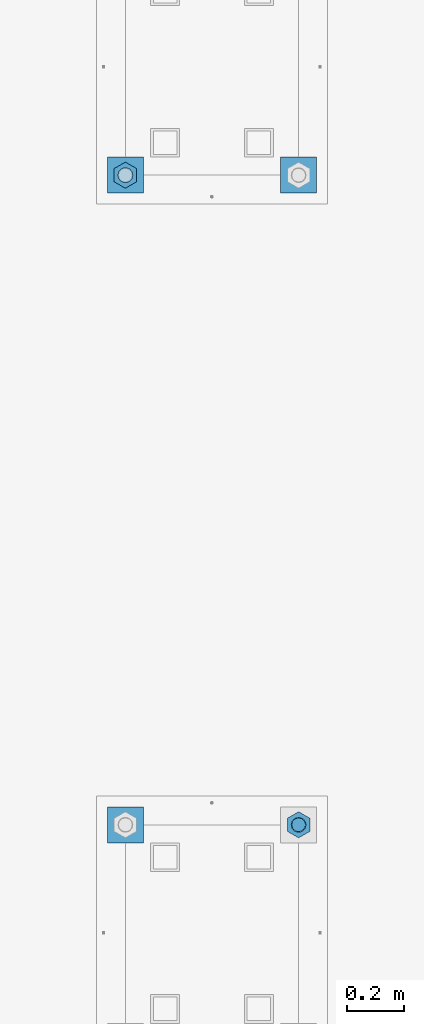
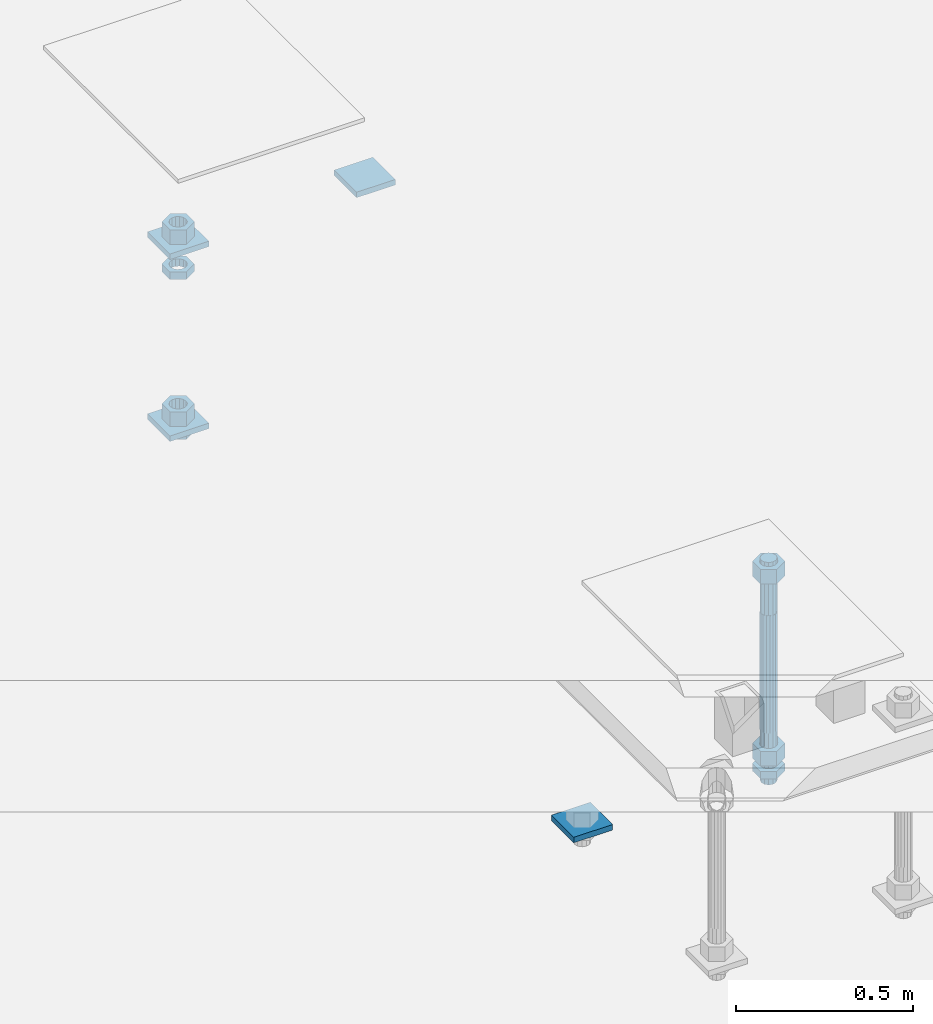
# One storey, part 2638 of 3843: 12 beams, 2 elements without a shape of their own.
"""IFC2X3 building model written with IfcOpenShell, lengths in millimetres."""

from ifc_helpers import new_model, si_unit, frame, origin_with_axes, place, context, subcontext, project, spatial, faceted_brep, material, type_object, element, aggregate, save


model = new_model("IFC2X3")

# Units and contexts
model_context = context("Model", 3, precision=1e-05, world=origin_with_axes())
body_context = subcontext(model_context, "Body", "Model", "MODEL_VIEW")
ifc_project = project(units=[si_unit("LENGTHUNIT", "METRE", prefix="MILLI"), si_unit("AREAUNIT", "SQUARE_METRE"), si_unit("VOLUMEUNIT", "CUBIC_METRE"), si_unit("MASSUNIT", "GRAM", prefix="KILO"), si_unit("TIMEUNIT", "SECOND"), si_unit("PLANEANGLEUNIT", "RADIAN"), si_unit("SOLIDANGLEUNIT", "STERADIAN"), si_unit("THERMODYNAMICTEMPERATUREUNIT", "DEGREE_CELSIUS"), si_unit("LUMINOUSINTENSITYUNIT", "LUMEN")], contexts=[model_context])

# Site, building, storey
site_placement = place(None, origin_with_axes())
site = spatial("IfcSite", under=ifc_project, at=site_placement, CompositionType="ELEMENT")
building_placement = place(site_placement, origin_with_axes())
building = spatial("IfcBuilding", under=site, at=building_placement, Name="Undefined", CompositionType="ELEMENT")
storey_placement = place(building_placement, origin_with_axes())
storey = spatial("IfcBuildingStorey", under=building, at=storey_placement, Name="Undefined", CompositionType="ELEMENT", Elevation=0.0)

# Assembly, beams
assembly_1_placement = place(storey_placement, origin_with_axes())
assembly_1 = element("IfcElementAssembly", 1, at=assembly_1_placement, inside=storey, Name="TEMPLATE", AssemblyPlace="NOTDEFINED", PredefinedType="RIGID_FRAME")
ifc_material_1 = material(Name="STEEL/A36")
beam_type_1 = type_object("IfcBeamType", PredefinedType="NOTDEFINED")
beam_1_placement = place(assembly_1_placement, frame((111798.099998474, 10121.9, 29873.575), z_axis=(0.0, 1.0, 0.0), x_axis=(-1.0, 0.0, 0.0)))
beam_1 = element("IfcBeam", 2, at=beam_1_placement, type_object=beam_type_1, material=ifc_material_1, Name="WASHER_PLATE", context=body_context, shape_type="Brep", body=[
    faceted_brep([(0.0, 9.52500000000146, -63.5), (0.0, 9.52500000000146, 63.5), (127.0, 9.52500000000146, 63.5), (127.0, 9.52500000000146, -63.5), (0.0, -9.52500000000146, 63.5), (127.0, -9.52500000000146, 63.5), (0.0, -9.52500000000146, -63.5), (127.0, -9.52500000000146, -63.5)], [[[0, 1, 2, 3]], [[1, 4, 5, 2]], [[4, 6, 7, 5]], [[6, 0, 3, 7]], [[5, 7, 3, 2]], [[6, 4, 1, 0]]]),
])
beam_2_placement = place(assembly_1_placement, frame((112407.7, 10121.9, 29873.575), z_axis=(0.0, 1.0, 0.0), x_axis=(-1.0, 0.0, 0.0)))
beam_2 = element("IfcBeam", 3, at=beam_2_placement, type_object=beam_type_1, material=ifc_material_1, Name="WASHER_PLATE", context=body_context, shape_type="Brep", body=[
    faceted_brep([(0.0, 9.52500000000146, -63.5), (0.0, 9.52500000000146, 63.5), (127.0, 9.52500000000146, 63.5), (127.0, 9.52500000000146, -63.5), (0.0, -9.52500000000146, 63.5), (127.0, -9.52500000000146, 63.5), (0.0, -9.52500000000146, -63.5), (127.0, -9.52500000000146, -63.5)], [[[0, 1, 2, 3]], [[1, 4, 5, 2]], [[4, 6, 7, 5]], [[6, 0, 3, 7]], [[5, 7, 3, 2]], [[6, 4, 1, 0]]]),
])
beam_3_placement = place(assembly_1_placement, frame((111798.099998474, 10121.9, 29244.925), z_axis=(0.0, 1.0, 0.0), x_axis=(-1.0, 0.0, 0.0)))
beam_3 = element("IfcBeam", 4, at=beam_3_placement, type_object=beam_type_1, material=ifc_material_1, Name="WASHER_PLATE", context=body_context, shape_type="Brep", body=[
    faceted_brep([(0.0, 9.52500000000146, -63.5), (0.0, 9.52500000000146, 63.5), (127.0, 9.52500000000146, 63.5), (127.0, 9.52500000000146, -63.5), (0.0, -9.52500000000146, 63.5), (127.0, -9.52500000000146, 63.5), (0.0, -9.52500000000146, -63.5), (127.0, -9.52500000000146, -63.5)], [[[0, 1, 2, 3]], [[1, 4, 5, 2]], [[4, 6, 7, 5]], [[6, 0, 3, 7]], [[5, 7, 3, 2]], [[6, 4, 1, 0]]]),
])

# Assembly, beam
assembly_2_placement = place(storey_placement, origin_with_axes())
assembly_2 = element("IfcElementAssembly", 5, at=assembly_2_placement, inside=storey, Name="TEMPLATE", AssemblyPlace="NOTDEFINED", PredefinedType="RIGID_FRAME")
beam_4_placement = place(assembly_2_placement, frame((111798.099998474, 7835.90000000001, 29244.925), z_axis=(0.0, 1.0, 0.0), x_axis=(-1.0, 0.0, 0.0)))
beam_4 = element("IfcBeam", 6, at=beam_4_placement, type_object=beam_type_1, material=ifc_material_1, Name="WASHER_PLATE", context=body_context, shape_type="Brep", body=[
    faceted_brep([(0.0, 9.52500000000146, -63.5), (0.0, 9.52500000000146, 63.5), (127.0, 9.52500000000146, 63.5), (127.0, 9.52500000000146, -63.5), (0.0, -9.52500000000146, 63.5), (127.0, -9.52500000000146, 63.5), (0.0, -9.52500000000146, -63.5), (127.0, -9.52500000000146, -63.5)], [[[0, 1, 2, 3]], [[1, 4, 5, 2]], [[4, 6, 7, 5]], [[6, 0, 3, 7]], [[5, 7, 3, 2]], [[6, 4, 1, 0]]]),
])

# Beam
beam_type_2 = type_object("IfcBeamType", Name="2_HALF_NUT", PredefinedType="NOTDEFINED")
beam_5_placement = place(assembly_1_placement, frame((111734.599998474, 10121.9, 29787.85), z_axis=(-1.0, 0.0, 0.0), x_axis=(0.0, 0.0, -1.0)))
beam_5 = element("IfcBeam", 7, at=beam_5_placement, type_object=beam_type_2, material=ifc_material_1, Name="NUT", ObjectType="2_HALF_NUT", context=body_context, shape_type="Brep", body=[
    faceted_brep([(0.0, -46.0369987487793, 0.0), (0.0, -23.0184993743896, -39.869213104248), (25.4000000000015, -23.0184993743896, -39.869213104248), (25.4000000000015, -46.0369987487793, 0.0), (0.0, 23.0184993743896, -39.869213104248), (25.4000000000015, 23.0184993743896, -39.869213104248), (0.0, 46.0369987487793, 0.0), (25.4000000000015, 46.0369987487793, 0.0), (0.0, 23.0184993743896, 39.869213104248), (25.4000000000015, 23.0184993743896, 39.869213104248), (0.0, -23.0184993743896, 39.869213104248), (25.4000000000015, -23.0184993743896, 39.869213104248), (0.0, 0.0, 26.1940002441406), (0.0, 11.3650617044477, 23.5999013092805), (25.4000000000015, 11.3650617044477, 23.5999013092805), (25.4000000000015, 0.0, 26.1940002441406), (0.0, 20.4791109456419, 16.3316083006721), (25.4000000000015, 20.4791109456419, 16.3316083006721), (0.0, 25.5370200498292, 5.82867859874386), (25.4000000000015, 25.5370200498292, 5.82867859874386), (0.0, 25.5370200498292, -5.82867859874386), (25.4000000000015, 25.5370200498292, -5.82867859874386), (0.0, 20.4791109456419, -16.3316083006721), (25.4000000000015, 20.4791109456419, -16.3316083006721), (0.0, 11.3650617044477, -23.5999013092805), (25.4000000000015, 11.3650617044477, -23.5999013092805), (0.0, 0.0, -26.1940002441406), (25.4000000000015, 0.0, -26.1940002441406), (0.0, -11.3650617044477, -23.5999013092805), (25.4000000000015, -11.3650617044477, -23.5999013092805), (0.0, -20.4791109456419, -16.3316083006721), (25.4000000000015, -20.4791109456419, -16.3316083006721), (0.0, -25.5370200498292, -5.82867859874386), (25.4000000000015, -25.5370200498292, -5.82867859874386), (0.0, -25.5370200498292, 5.82867859874386), (25.4000000000015, -25.5370200498292, 5.82867859874386), (0.0, -20.4791109456419, 16.3316083006721), (25.4000000000015, -20.4791109456419, 16.3316083006721), (0.0, -11.3650617044477, 23.5999013092805), (25.4000000000015, -11.3650617044477, 23.5999013092805)], [[[0, 1, 2, 3]], [[1, 4, 5, 2]], [[4, 6, 7, 5]], [[6, 8, 9, 7]], [[8, 10, 11, 9]], [[10, 0, 3, 11]], [[12, 13, 14, 15]], [[13, 16, 17, 14]], [[16, 18, 19, 17]], [[18, 20, 21, 19]], [[20, 22, 23, 21]], [[22, 24, 25, 23]], [[24, 26, 27, 25]], [[26, 28, 29, 27]], [[28, 30, 31, 29]], [[30, 32, 33, 31]], [[32, 34, 35, 33]], [[34, 36, 37, 35]], [[36, 38, 39, 37]], [[38, 12, 15, 39]], [[5, 7, 9, 11, 3, 2], [17, 19, 21, 23, 25, 27, 29, 31, 33, 35, 37, 39, 15, 14]], [[10, 8, 6, 4, 1, 0], [38, 36, 34, 32, 30, 28, 26, 24, 22, 20, 18, 16, 13, 12]]]),
])

beam_6_placement = place(assembly_1_placement, frame((111734.599998474, 10121.9, 29235.4), z_axis=(-1.0, 0.0, 0.0), x_axis=(0.0, 0.0, -1.0)))
beam_6 = element("IfcBeam", 8, at=beam_6_placement, type_object=beam_type_2, material=ifc_material_1, Name="NUT", ObjectType="2_HALF_NUT", context=body_context, shape_type="Brep", body=[
    faceted_brep([(0.0, -46.0369987487793, 0.0), (0.0, -23.0184993743896, -39.869213104248), (25.4000000000015, -23.0184993743896, -39.869213104248), (25.4000000000015, -46.0369987487793, 0.0), (0.0, 23.0184993743896, -39.869213104248), (25.4000000000015, 23.0184993743896, -39.869213104248), (0.0, 46.0369987487793, 0.0), (25.4000000000015, 46.0369987487793, 0.0), (0.0, 23.0184993743896, 39.869213104248), (25.4000000000015, 23.0184993743896, 39.869213104248), (0.0, -23.0184993743896, 39.869213104248), (25.4000000000015, -23.0184993743896, 39.869213104248), (0.0, 0.0, 26.1940002441406), (0.0, 11.3650617044477, 23.5999013092805), (25.4000000000015, 11.3650617044477, 23.5999013092805), (25.4000000000015, 0.0, 26.1940002441406), (0.0, 20.4791109456419, 16.3316083006721), (25.4000000000015, 20.4791109456419, 16.3316083006721), (0.0, 25.5370200498292, 5.82867859874386), (25.4000000000015, 25.5370200498292, 5.82867859874386), (0.0, 25.5370200498292, -5.82867859874386), (25.4000000000015, 25.5370200498292, -5.82867859874386), (0.0, 20.4791109456419, -16.3316083006721), (25.4000000000015, 20.4791109456419, -16.3316083006721), (0.0, 11.3650617044477, -23.5999013092805), (25.4000000000015, 11.3650617044477, -23.5999013092805), (0.0, 0.0, -26.1940002441406), (25.4000000000015, 0.0, -26.1940002441406), (0.0, -11.3650617044477, -23.5999013092805), (25.4000000000015, -11.3650617044477, -23.5999013092805), (0.0, -20.4791109456419, -16.3316083006721), (25.4000000000015, -20.4791109456419, -16.3316083006721), (0.0, -25.5370200498292, -5.82867859874386), (25.4000000000015, -25.5370200498292, -5.82867859874386), (0.0, -25.5370200498292, 5.82867859874386), (25.4000000000015, -25.5370200498292, 5.82867859874386), (0.0, -20.4791109456419, 16.3316083006721), (25.4000000000015, -20.4791109456419, 16.3316083006721), (0.0, -11.3650617044477, 23.5999013092805), (25.4000000000015, -11.3650617044477, 23.5999013092805)], [[[0, 1, 2, 3]], [[1, 4, 5, 2]], [[4, 6, 7, 5]], [[6, 8, 9, 7]], [[8, 10, 11, 9]], [[10, 0, 3, 11]], [[12, 13, 14, 15]], [[13, 16, 17, 14]], [[16, 18, 19, 17]], [[18, 20, 21, 19]], [[20, 22, 23, 21]], [[22, 24, 25, 23]], [[24, 26, 27, 25]], [[26, 28, 29, 27]], [[28, 30, 31, 29]], [[30, 32, 33, 31]], [[32, 34, 35, 33]], [[34, 36, 37, 35]], [[36, 38, 39, 37]], [[38, 12, 15, 39]], [[5, 7, 9, 11, 3, 2], [17, 19, 21, 23, 25, 27, 29, 31, 33, 35, 37, 39, 15, 14]], [[10, 8, 6, 4, 1, 0], [38, 36, 34, 32, 30, 28, 26, 24, 22, 20, 18, 16, 13, 12]]]),
])

beam_7_placement = place(assembly_2_placement, frame((112344.2, 7835.9, 29235.4), z_axis=(-1.0, 0.0, 0.0), x_axis=(0.0, 0.0, -1.0)))
beam_7 = element("IfcBeam", 9, at=beam_7_placement, type_object=beam_type_2, material=ifc_material_1, Name="NUT", ObjectType="2_HALF_NUT", context=body_context, shape_type="Brep", body=[
    faceted_brep([(0.0, -46.0369987487793, 0.0), (0.0, -23.0184993743896, -39.869213104248), (25.4000000000015, -23.0184993743896, -39.869213104248), (25.4000000000015, -46.0369987487793, 0.0), (0.0, 23.0184993743896, -39.869213104248), (25.4000000000015, 23.0184993743896, -39.869213104248), (0.0, 46.0369987487793, 0.0), (25.4000000000015, 46.0369987487793, 0.0), (0.0, 23.0184993743896, 39.869213104248), (25.4000000000015, 23.0184993743896, 39.869213104248), (0.0, -23.0184993743896, 39.869213104248), (25.4000000000015, -23.0184993743896, 39.869213104248), (0.0, 0.0, 26.1940002441406), (0.0, 11.3650617044477, 23.5999013092805), (25.4000000000015, 11.3650617044477, 23.5999013092805), (25.4000000000015, 0.0, 26.1940002441406), (0.0, 20.4791109456419, 16.3316083006721), (25.4000000000015, 20.4791109456419, 16.3316083006721), (0.0, 25.5370200498292, 5.82867859874386), (25.4000000000015, 25.5370200498292, 5.82867859874386), (0.0, 25.5370200498292, -5.82867859874386), (25.4000000000015, 25.5370200498292, -5.82867859874386), (0.0, 20.4791109456419, -16.3316083006721), (25.4000000000015, 20.4791109456419, -16.3316083006721), (0.0, 11.3650617044477, -23.5999013092805), (25.4000000000015, 11.3650617044477, -23.5999013092805), (0.0, 0.0, -26.1940002441406), (25.4000000000015, 0.0, -26.1940002441406), (0.0, -11.3650617044477, -23.5999013092805), (25.4000000000015, -11.3650617044477, -23.5999013092805), (0.0, -20.4791109456419, -16.3316083006721), (25.4000000000015, -20.4791109456419, -16.3316083006721), (0.0, -25.5370200498292, -5.82867859874386), (25.4000000000015, -25.5370200498292, -5.82867859874386), (0.0, -25.5370200498292, 5.82867859874386), (25.4000000000015, -25.5370200498292, 5.82867859874386), (0.0, -20.4791109456419, 16.3316083006721), (25.4000000000015, -20.4791109456419, 16.3316083006721), (0.0, -11.3650617044477, 23.5999013092805), (25.4000000000015, -11.3650617044477, 23.5999013092805)], [[[0, 1, 2, 3]], [[1, 4, 5, 2]], [[4, 6, 7, 5]], [[6, 8, 9, 7]], [[8, 10, 11, 9]], [[10, 0, 3, 11]], [[12, 13, 14, 15]], [[13, 16, 17, 14]], [[16, 18, 19, 17]], [[18, 20, 21, 19]], [[20, 22, 23, 21]], [[22, 24, 25, 23]], [[24, 26, 27, 25]], [[26, 28, 29, 27]], [[28, 30, 31, 29]], [[30, 32, 33, 31]], [[32, 34, 35, 33]], [[34, 36, 37, 35]], [[36, 38, 39, 37]], [[38, 12, 15, 39]], [[5, 7, 9, 11, 3, 2], [17, 19, 21, 23, 25, 27, 29, 31, 33, 35, 37, 39, 15, 14]], [[10, 8, 6, 4, 1, 0], [38, 36, 34, 32, 30, 28, 26, 24, 22, 20, 18, 16, 13, 12]]]),
])

beam_type_3 = type_object("IfcBeamType", Name="2_HEAVY_HEX_NUT", PredefinedType="NOTDEFINED")
beam_8_placement = place(assembly_1_placement, frame((111734.599998474, 10121.9, 29933.9), z_axis=(-1.0, 0.0, 0.0), x_axis=(0.0, 0.0, -1.0)))
beam_8 = element("IfcBeam", 10, at=beam_8_placement, type_object=beam_type_3, material=ifc_material_1, Name="NUT", ObjectType="2_HEAVY_HEX_NUT", context=body_context, shape_type="Brep", body=[
    faceted_brep([(0.0, -46.0369987487793, 0.0), (0.0, -23.0184993743896, -39.869213104248), (50.7999999999993, -23.0184993743896, -39.869213104248), (50.7999999999993, -46.0369987487793, 0.0), (0.0, 23.0184993743896, -39.869213104248), (50.7999999999993, 23.0184993743896, -39.869213104248), (0.0, 46.0369987487793, 0.0), (50.7999999999993, 46.0369987487793, 0.0), (0.0, 23.0184993743896, 39.869213104248), (50.7999999999993, 23.0184993743896, 39.869213104248), (0.0, -23.0184993743896, 39.869213104248), (50.7999999999993, -23.0184993743896, 39.869213104248), (0.0, 0.0, 26.1940002441406), (0.0, 11.3650617044477, 23.5999013092805), (50.7999999999993, 11.3650617044477, 23.5999013092805), (50.7999999999993, 0.0, 26.1940002441406), (0.0, 20.4791109456419, 16.3316083006721), (50.7999999999993, 20.4791109456419, 16.3316083006721), (0.0, 25.5370200498292, 5.82867859874386), (50.7999999999993, 25.5370200498292, 5.82867859874386), (0.0, 25.5370200498292, -5.82867859874386), (50.7999999999993, 25.5370200498292, -5.82867859874386), (0.0, 20.4791109456419, -16.3316083006721), (50.7999999999993, 20.4791109456419, -16.3316083006721), (0.0, 11.3650617044477, -23.5999013092805), (50.7999999999993, 11.3650617044477, -23.5999013092805), (0.0, 0.0, -26.1940002441406), (50.7999999999993, 0.0, -26.1940002441406), (0.0, -11.3650617044477, -23.5999013092805), (50.7999999999993, -11.3650617044477, -23.5999013092805), (0.0, -20.4791109456419, -16.3316083006721), (50.7999999999993, -20.4791109456419, -16.3316083006721), (0.0, -25.5370200498292, -5.82867859874386), (50.7999999999993, -25.5370200498292, -5.82867859874386), (0.0, -25.5370200498292, 5.82867859874386), (50.7999999999993, -25.5370200498292, 5.82867859874386), (0.0, -20.4791109456419, 16.3316083006721), (50.7999999999993, -20.4791109456419, 16.3316083006721), (0.0, -11.3650617044477, 23.5999013092805), (50.7999999999993, -11.3650617044477, 23.5999013092805)], [[[0, 1, 2, 3]], [[1, 4, 5, 2]], [[4, 6, 7, 5]], [[6, 8, 9, 7]], [[8, 10, 11, 9]], [[10, 0, 3, 11]], [[12, 13, 14, 15]], [[13, 16, 17, 14]], [[16, 18, 19, 17]], [[18, 20, 21, 19]], [[20, 22, 23, 21]], [[22, 24, 25, 23]], [[24, 26, 27, 25]], [[26, 28, 29, 27]], [[28, 30, 31, 29]], [[30, 32, 33, 31]], [[32, 34, 35, 33]], [[34, 36, 37, 35]], [[36, 38, 39, 37]], [[38, 12, 15, 39]], [[5, 7, 9, 11, 3, 2], [17, 19, 21, 23, 25, 27, 29, 31, 33, 35, 37, 39, 15, 14]], [[10, 8, 6, 4, 1, 0], [38, 36, 34, 32, 30, 28, 26, 24, 22, 20, 18, 16, 13, 12]]]),
])

beam_9_placement = place(assembly_1_placement, frame((111734.599998474, 10121.9, 29305.25), z_axis=(-1.0, 0.0, 0.0), x_axis=(0.0, 0.0, -1.0)))
beam_9 = element("IfcBeam", 11, at=beam_9_placement, type_object=beam_type_3, material=ifc_material_1, Name="NUT", ObjectType="2_HEAVY_HEX_NUT", context=body_context, shape_type="Brep", body=[
    faceted_brep([(0.0, -46.0369987487793, 0.0), (0.0, -23.0184993743896, -39.869213104248), (50.7999999999993, -23.0184993743896, -39.869213104248), (50.7999999999993, -46.0369987487793, 0.0), (0.0, 23.0184993743896, -39.869213104248), (50.7999999999993, 23.0184993743896, -39.869213104248), (0.0, 46.0369987487793, 0.0), (50.7999999999993, 46.0369987487793, 0.0), (0.0, 23.0184993743896, 39.869213104248), (50.7999999999993, 23.0184993743896, 39.869213104248), (0.0, -23.0184993743896, 39.869213104248), (50.7999999999993, -23.0184993743896, 39.869213104248), (0.0, 0.0, 26.1940002441406), (0.0, 11.3650617044477, 23.5999013092805), (50.7999999999993, 11.3650617044477, 23.5999013092805), (50.7999999999993, 0.0, 26.1940002441406), (0.0, 20.4791109456419, 16.3316083006721), (50.7999999999993, 20.4791109456419, 16.3316083006721), (0.0, 25.5370200498292, 5.82867859874386), (50.7999999999993, 25.5370200498292, 5.82867859874386), (0.0, 25.5370200498292, -5.82867859874386), (50.7999999999993, 25.5370200498292, -5.82867859874386), (0.0, 20.4791109456419, -16.3316083006721), (50.7999999999993, 20.4791109456419, -16.3316083006721), (0.0, 11.3650617044477, -23.5999013092805), (50.7999999999993, 11.3650617044477, -23.5999013092805), (0.0, 0.0, -26.1940002441406), (50.7999999999993, 0.0, -26.1940002441406), (0.0, -11.3650617044477, -23.5999013092805), (50.7999999999993, -11.3650617044477, -23.5999013092805), (0.0, -20.4791109456419, -16.3316083006721), (50.7999999999993, -20.4791109456419, -16.3316083006721), (0.0, -25.5370200498292, -5.82867859874386), (50.7999999999993, -25.5370200498292, -5.82867859874386), (0.0, -25.5370200498292, 5.82867859874386), (50.7999999999993, -25.5370200498292, 5.82867859874386), (0.0, -20.4791109456419, 16.3316083006721), (50.7999999999993, -20.4791109456419, 16.3316083006721), (0.0, -11.3650617044477, 23.5999013092805), (50.7999999999993, -11.3650617044477, 23.5999013092805)], [[[0, 1, 2, 3]], [[1, 4, 5, 2]], [[4, 6, 7, 5]], [[6, 8, 9, 7]], [[8, 10, 11, 9]], [[10, 0, 3, 11]], [[12, 13, 14, 15]], [[13, 16, 17, 14]], [[16, 18, 19, 17]], [[18, 20, 21, 19]], [[20, 22, 23, 21]], [[22, 24, 25, 23]], [[24, 26, 27, 25]], [[26, 28, 29, 27]], [[28, 30, 31, 29]], [[30, 32, 33, 31]], [[32, 34, 35, 33]], [[34, 36, 37, 35]], [[36, 38, 39, 37]], [[38, 12, 15, 39]], [[5, 7, 9, 11, 3, 2], [17, 19, 21, 23, 25, 27, 29, 31, 33, 35, 37, 39, 15, 14]], [[10, 8, 6, 4, 1, 0], [38, 36, 34, 32, 30, 28, 26, 24, 22, 20, 18, 16, 13, 12]]]),
])

aggregate(assembly_1, [beam_1, beam_2, beam_3, beam_5, beam_8, beam_9, beam_6])

beam_10_placement = place(assembly_2_placement, frame((112344.2, 7835.90000000001, 29933.9), z_axis=(-1.0, 0.0, 0.0), x_axis=(0.0, 0.0, -1.0)))
beam_10 = element("IfcBeam", 12, at=beam_10_placement, type_object=beam_type_3, material=ifc_material_1, Name="NUT", ObjectType="2_HEAVY_HEX_NUT", context=body_context, shape_type="Brep", body=[
    faceted_brep([(0.0, -46.0369987487793, 0.0), (0.0, -23.0184993743896, -39.869213104248), (50.7999999999993, -23.0184993743896, -39.869213104248), (50.7999999999993, -46.0369987487793, 0.0), (0.0, 23.0184993743896, -39.869213104248), (50.7999999999993, 23.0184993743896, -39.869213104248), (0.0, 46.0369987487793, 0.0), (50.7999999999993, 46.0369987487793, 0.0), (0.0, 23.0184993743896, 39.869213104248), (50.7999999999993, 23.0184993743896, 39.869213104248), (0.0, -23.0184993743896, 39.869213104248), (50.7999999999993, -23.0184993743896, 39.869213104248), (0.0, 0.0, 26.1940002441406), (0.0, 11.3650617044477, 23.5999013092805), (50.7999999999993, 11.3650617044477, 23.5999013092805), (50.7999999999993, 0.0, 26.1940002441406), (0.0, 20.4791109456419, 16.3316083006721), (50.7999999999993, 20.4791109456419, 16.3316083006721), (0.0, 25.5370200498292, 5.82867859874386), (50.7999999999993, 25.5370200498292, 5.82867859874386), (0.0, 25.5370200498292, -5.82867859874386), (50.7999999999993, 25.5370200498292, -5.82867859874386), (0.0, 20.4791109456419, -16.3316083006721), (50.7999999999993, 20.4791109456419, -16.3316083006721), (0.0, 11.3650617044477, -23.5999013092805), (50.7999999999993, 11.3650617044477, -23.5999013092805), (0.0, 0.0, -26.1940002441406), (50.7999999999993, 0.0, -26.1940002441406), (0.0, -11.3650617044477, -23.5999013092805), (50.7999999999993, -11.3650617044477, -23.5999013092805), (0.0, -20.4791109456419, -16.3316083006721), (50.7999999999993, -20.4791109456419, -16.3316083006721), (0.0, -25.5370200498292, -5.82867859874386), (50.7999999999993, -25.5370200498292, -5.82867859874386), (0.0, -25.5370200498292, 5.82867859874386), (50.7999999999993, -25.5370200498292, 5.82867859874386), (0.0, -20.4791109456419, 16.3316083006721), (50.7999999999993, -20.4791109456419, 16.3316083006721), (0.0, -11.3650617044477, 23.5999013092805), (50.7999999999993, -11.3650617044477, 23.5999013092805)], [[[0, 1, 2, 3]], [[1, 4, 5, 2]], [[4, 6, 7, 5]], [[6, 8, 9, 7]], [[8, 10, 11, 9]], [[10, 0, 3, 11]], [[12, 13, 14, 15]], [[13, 16, 17, 14]], [[16, 18, 19, 17]], [[18, 20, 21, 19]], [[20, 22, 23, 21]], [[22, 24, 25, 23]], [[24, 26, 27, 25]], [[26, 28, 29, 27]], [[28, 30, 31, 29]], [[30, 32, 33, 31]], [[32, 34, 35, 33]], [[34, 36, 37, 35]], [[36, 38, 39, 37]], [[38, 12, 15, 39]], [[5, 7, 9, 11, 3, 2], [17, 19, 21, 23, 25, 27, 29, 31, 33, 35, 37, 39, 15, 14]], [[10, 8, 6, 4, 1, 0], [38, 36, 34, 32, 30, 28, 26, 24, 22, 20, 18, 16, 13, 12]]]),
])

beam_11_placement = place(assembly_2_placement, frame((112344.2, 7835.90000000001, 29305.25), z_axis=(-1.0, 0.0, 0.0), x_axis=(0.0, 0.0, -1.0)))
beam_11 = element("IfcBeam", 13, at=beam_11_placement, type_object=beam_type_3, material=ifc_material_1, Name="NUT", ObjectType="2_HEAVY_HEX_NUT", context=body_context, shape_type="Brep", body=[
    faceted_brep([(0.0, -46.0369987487793, 0.0), (0.0, -23.0184993743896, -39.869213104248), (50.7999999999993, -23.0184993743896, -39.869213104248), (50.7999999999993, -46.0369987487793, 0.0), (0.0, 23.0184993743896, -39.869213104248), (50.7999999999993, 23.0184993743896, -39.869213104248), (0.0, 46.0369987487793, 0.0), (50.7999999999993, 46.0369987487793, 0.0), (0.0, 23.0184993743896, 39.869213104248), (50.7999999999993, 23.0184993743896, 39.869213104248), (0.0, -23.0184993743896, 39.869213104248), (50.7999999999993, -23.0184993743896, 39.869213104248), (0.0, 0.0, 26.1940002441406), (0.0, 11.3650617044477, 23.5999013092805), (50.7999999999993, 11.3650617044477, 23.5999013092805), (50.7999999999993, 0.0, 26.1940002441406), (0.0, 20.4791109456419, 16.3316083006721), (50.7999999999993, 20.4791109456419, 16.3316083006721), (0.0, 25.5370200498292, 5.82867859874386), (50.7999999999993, 25.5370200498292, 5.82867859874386), (0.0, 25.5370200498292, -5.82867859874386), (50.7999999999993, 25.5370200498292, -5.82867859874386), (0.0, 20.4791109456419, -16.3316083006721), (50.7999999999993, 20.4791109456419, -16.3316083006721), (0.0, 11.3650617044477, -23.5999013092805), (50.7999999999993, 11.3650617044477, -23.5999013092805), (0.0, 0.0, -26.1940002441406), (50.7999999999993, 0.0, -26.1940002441406), (0.0, -11.3650617044477, -23.5999013092805), (50.7999999999993, -11.3650617044477, -23.5999013092805), (0.0, -20.4791109456419, -16.3316083006721), (50.7999999999993, -20.4791109456419, -16.3316083006721), (0.0, -25.5370200498292, -5.82867859874386), (50.7999999999993, -25.5370200498292, -5.82867859874386), (0.0, -25.5370200498292, 5.82867859874386), (50.7999999999993, -25.5370200498292, 5.82867859874386), (0.0, -20.4791109456419, 16.3316083006721), (50.7999999999993, -20.4791109456419, 16.3316083006721), (0.0, -11.3650617044477, 23.5999013092805), (50.7999999999993, -11.3650617044477, 23.5999013092805)], [[[0, 1, 2, 3]], [[1, 4, 5, 2]], [[4, 6, 7, 5]], [[6, 8, 9, 7]], [[8, 10, 11, 9]], [[10, 0, 3, 11]], [[12, 13, 14, 15]], [[13, 16, 17, 14]], [[16, 18, 19, 17]], [[18, 20, 21, 19]], [[20, 22, 23, 21]], [[22, 24, 25, 23]], [[24, 26, 27, 25]], [[26, 28, 29, 27]], [[28, 30, 31, 29]], [[30, 32, 33, 31]], [[32, 34, 35, 33]], [[34, 36, 37, 35]], [[36, 38, 39, 37]], [[38, 12, 15, 39]], [[5, 7, 9, 11, 3, 2], [17, 19, 21, 23, 25, 27, 29, 31, 33, 35, 37, 39, 15, 14]], [[10, 8, 6, 4, 1, 0], [38, 36, 34, 32, 30, 28, 26, 24, 22, 20, 18, 16, 13, 12]]]),
])

ifc_material_2 = material()
beam_type_4 = type_object("IfcBeamType", PredefinedType="NOTDEFINED")
beam_12_placement = place(assembly_2_placement, frame((112344.2, 7835.90000000001, 29762.45), z_axis=(-1.0, 0.0, 0.0), x_axis=(0.0, 0.0, -1.0)))
beam_12 = element("IfcBeam", 14, at=beam_12_placement, type_object=beam_type_4, material=ifc_material_2, Name="ANCHOR_ROD", context=body_context, shape_type="Brep", body=[
    faceted_brep([(-184.150000000001, -21.217622392709, 12.25), (-184.150000000001, -12.2499999999854, 21.2176223927163), (-184.150000000001, 1.45519152283669e-11, 24.5), (-184.150000000001, 12.2500000000146, 21.2176223927163), (-184.150000000001, 21.2176223927381, 12.25), (-184.150000000001, 24.5000000000146, 0.0), (-184.150000000001, 21.2176223927381, -12.25), (-184.150000000001, 12.2500000000146, -21.2176223927163), (-184.150000000001, 1.45519152283669e-11, -24.5), (-184.150000000001, -12.2499999999854, -21.2176223927163), (-184.150000000001, -21.217622392709, -12.25), (-184.150000000001, -24.4999999999854, 0.0), (0.0, 24.5000000000146, 0.0), (0.0, 21.2176223927381, -12.25), (0.0, 12.2500000000146, -21.2176223927163), (0.0, 1.45519152283669e-11, -24.5), (0.0, -12.2499999999854, -21.2176223927163), (0.0, -21.217622392709, -12.25), (0.0, -24.4999999999854, 0.0), (0.0, -21.217622392709, 12.25), (0.0, -12.2499999999854, 21.2176223927163), (0.0, 1.45519152283669e-11, 24.5), (0.0, 12.2500000000146, 21.2176223927163), (0.0, 21.2176223927381, 12.25), (0.0, -23.4665401257807, 9.72015918207035), (0.0, -17.9605122421344, 17.9605122421417), (0.0, -9.72015918207762, 23.466540125788), (0.0, 0.0, 25.4000000000015), (0.0, 9.72015918207762, 23.466540125788), (0.0, 17.9605122421344, 17.9605122421417), (0.0, 23.4665401257807, 9.72015918207035), (0.0, 25.3999996185303, 0.0), (0.0, 23.4665401257807, -9.72015918207035), (0.0, 17.9605122421344, -17.9605122421417), (0.0, 9.72015918207762, -23.466540125788), (0.0, 0.0, -25.4000000000015), (0.0, -9.72015918207762, -23.466540125788), (0.0, -17.9605122421344, -17.9605122421417), (0.0, -23.4665401257807, -9.72015918207035), (0.0, -25.3999996185303, 0.0), (406.399999999998, -25.3999999999942, 0.0), (406.399999999998, -23.4665401257807, 9.72015918207035), (406.399999999998, -17.9605122421344, 17.9605122421417), (406.399999999998, -9.72015918207762, 23.466540125788), (406.399999999998, 0.0, 25.4000000000015), (406.399999999998, 9.72015918207762, 23.466540125788), (406.399999999998, 17.9605122421344, 17.9605122421417), (406.399999999998, 23.4665401257807, 9.72015918207035), (406.399999999998, 25.3999999999942, 0.0), (406.399999999998, 23.4665401257807, -9.72015918207035), (406.399999999998, 17.9605122421344, -17.9605122421417), (406.399999999998, 9.72015918207762, -23.466540125788), (406.399999999998, 0.0, -25.4000000000015), (406.399999999998, -9.72015918207762, -23.466540125788), (406.399999999998, -17.9605122421344, -17.9605122421417), (406.399999999998, -23.4665401257807, -9.72015918207035), (406.399999999998, -12.2499999999854, 21.2176223927163), (406.399999999998, 1.45519152283669e-11, 24.5), (406.399999999998, 12.2500000000146, 21.2176223927163), (406.399999999998, 21.2176223927381, 12.25), (406.399999999998, 24.5000000000146, 0.0), (406.399999999998, 21.2176223927381, -12.25), (406.399999999998, 12.2500000000146, -21.2176223927163), (406.399999999998, 1.45519152283669e-11, -24.5), (406.399999999998, -12.2499999999854, -21.2176223927163), (406.399999999998, -21.217622392709, -12.25), (406.399999999998, -24.4999999999854, 0.0), (406.399999999998, -21.217622392709, 12.25), (584.200000000001, -12.2499999999854, -21.2176223927163), (584.200000000001, 1.45519152283669e-11, -24.5), (584.200000000001, 12.2500000000146, -21.2176223927163), (584.200000000001, 21.2176223927381, -12.25), (584.200000000001, 24.5000000000146, 0.0), (584.200000000001, 21.2176223927381, 12.25), (584.200000000001, 12.2500000000146, 21.2176223927163), (584.200000000001, 1.45519152283669e-11, 24.5), (584.200000000001, -12.2499999999854, 21.2176223927163), (584.200000000001, -21.217622392709, 12.25), (584.200000000001, -24.4999999999854, 0.0), (584.200000000001, -21.217622392709, -12.25)], [[[0, 1, 2, 3, 4, 5, 6, 7, 8, 9, 10, 11]], [[6, 5, 12, 13]], [[7, 6, 13, 14]], [[8, 7, 14, 15]], [[9, 8, 15, 16]], [[10, 9, 16, 17]], [[11, 10, 17, 18]], [[0, 11, 18, 19]], [[1, 0, 19, 20]], [[2, 1, 20, 21]], [[3, 2, 21, 22]], [[4, 3, 22, 23]], [[5, 4, 23, 12]], [[24, 25, 26, 27, 28, 29, 30, 31, 32, 33, 34, 35, 36, 37, 38, 39], [22, 21, 20, 19, 18, 17, 16, 15, 14, 13, 12, 23]], [[24, 39, 40, 41]], [[25, 24, 41, 42]], [[26, 25, 42, 43]], [[27, 26, 43, 44]], [[28, 27, 44, 45]], [[29, 28, 45, 46]], [[30, 29, 46, 47]], [[31, 30, 47, 48]], [[32, 31, 48, 49]], [[33, 32, 49, 50]], [[34, 33, 50, 51]], [[35, 34, 51, 52]], [[36, 35, 52, 53]], [[37, 36, 53, 54]], [[38, 37, 54, 55]], [[39, 38, 55, 40]], [[54, 53, 52, 51, 50, 49, 48, 47, 46, 45, 44, 43, 42, 41, 40, 55], [56, 57, 58, 59, 60, 61, 62, 63, 64, 65, 66, 67]], [[68, 69, 70, 71, 72, 73, 74, 75, 76, 77, 78, 79]], [[76, 75, 57, 56]], [[77, 76, 56, 67]], [[78, 77, 67, 66]], [[79, 78, 66, 65]], [[68, 79, 65, 64]], [[69, 68, 64, 63]], [[70, 69, 63, 62]], [[71, 70, 62, 61]], [[72, 71, 61, 60]], [[73, 72, 60, 59]], [[74, 73, 59, 58]], [[75, 74, 58, 57]]]),
])

aggregate(assembly_2, [beam_10, beam_11, beam_7, beam_12, beam_4])

save(model, "model.ifc")
